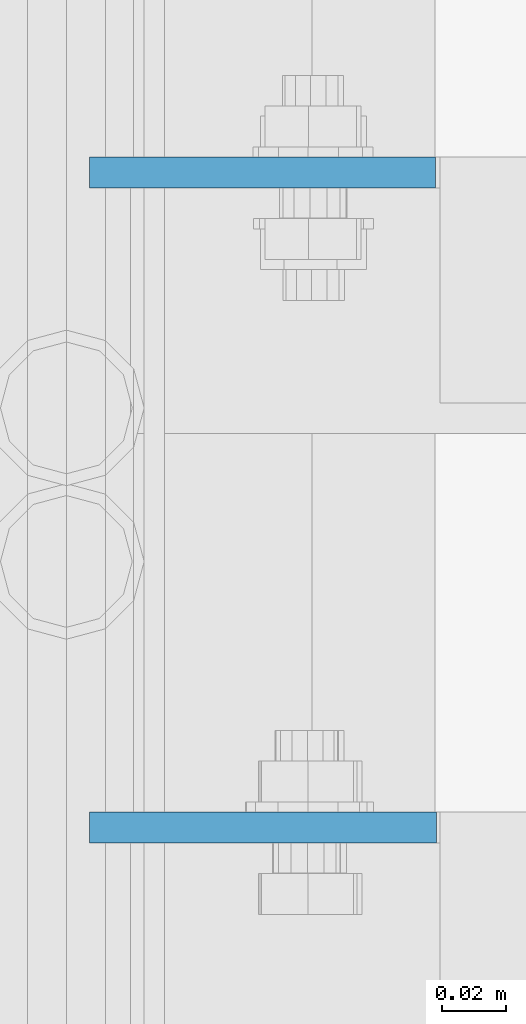
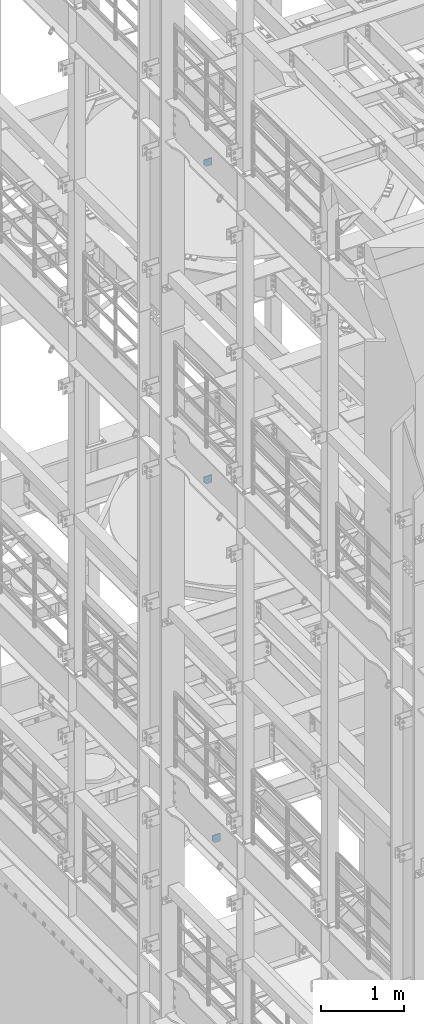
# One storey, part 1686 of 1876: 3 plates, 3 elements without a shape of their own.
"""IFC2X3 building model written with IfcOpenShell, lengths in millimetres."""

from ifc_helpers import new_model, si_unit, frame, origin_with_axes, place, context, subcontext, project, spatial, faceted_brep, material, type_object, element, aggregate, save


model = new_model("IFC2X3")

# Units and contexts
model_context = context("Model", 3, precision=1e-05, world=origin_with_axes())
body_context = subcontext(model_context, "Body", "Model", "MODEL_VIEW")
ifc_project = project(units=[si_unit("LENGTHUNIT", "METRE", prefix="MILLI"), si_unit("AREAUNIT", "SQUARE_METRE"), si_unit("VOLUMEUNIT", "CUBIC_METRE"), si_unit("MASSUNIT", "GRAM", prefix="KILO"), si_unit("TIMEUNIT", "SECOND"), si_unit("PLANEANGLEUNIT", "RADIAN"), si_unit("SOLIDANGLEUNIT", "STERADIAN"), si_unit("THERMODYNAMICTEMPERATUREUNIT", "DEGREE_CELSIUS"), si_unit("LUMINOUSINTENSITYUNIT", "LUMEN")], contexts=[model_context])

# Site, building, storey
site_placement = place(None, origin_with_axes())
site = spatial("IfcSite", under=ifc_project, at=site_placement, CompositionType="ELEMENT")
building_placement = place(site_placement, origin_with_axes())
building = spatial("IfcBuilding", under=site, at=building_placement, Name="Undefined", CompositionType="ELEMENT")
storey_placement = place(building_placement, origin_with_axes())
storey = spatial("IfcBuildingStorey", under=building, at=storey_placement, Name="Undefined", CompositionType="ELEMENT", Elevation=0.0)

# Assembly, plate
assembly_1_placement = place(storey_placement, origin_with_axes())
assembly_1 = element("IfcElementAssembly", 1, at=assembly_1_placement, inside=storey, Name="BEAM", AssemblyPlace="NOTDEFINED", PredefinedType="RIGID_FRAME")
ifc_material = material(Name="STEEL/A36")
plate_type_1 = type_object("IfcPlateType", PredefinedType="NOTDEFINED")
plate_1_placement = place(assembly_1_placement, frame((114.570656047482, 6599.2375, 17386.3), z_axis=(-1.0, 0.0, 0.0), x_axis=(0.0, 0.0, 1.0)))
plate_1 = element("IfcPlate", 2, at=plate_1_placement, type_object=plate_type_1, material=ifc_material, Name="PLATE", context=body_context, shape_type="Brep", body=[
    faceted_brep([(0.0, -4.76249999999982, 0.0), (0.0, -4.76249999999982, 75.6769027709961), (0.0, 4.76249999999982, 75.6769027709961), (0.0, 4.76249999999982, 0.0), (31.75, -4.76249999999982, 107.426902770996), (31.75, 4.76249999999982, 107.426902770996), (106.270881652832, -4.76249999999982, 107.426902770996), (106.270881652832, 4.76249999999982, 107.426902770996), (106.270881652832, -4.76249999999982, 0.0), (106.270881652832, 4.76249999999982, 0.0)], [[[0, 1, 2, 3]], [[1, 4, 5, 2]], [[4, 6, 7, 5]], [[6, 8, 9, 7]], [[8, 0, 3, 9]], [[5, 7, 9, 3, 2]], [[8, 6, 4, 1, 0]]]),
])
aggregate(assembly_1, [plate_1])

assembly_2_placement = place(storey_placement, origin_with_axes())
assembly_2 = element("IfcElementAssembly", 3, at=assembly_2_placement, inside=storey, Name="BEAM", AssemblyPlace="NOTDEFINED", PredefinedType="RIGID_FRAME")
plate_type_2 = type_object("IfcPlateType", PredefinedType="NOTDEFINED")
plate_2_placement = place(assembly_2_placement, frame((7.14375, 6396.0375, 7556.5), z_axis=(0.0, 0.0, 1.0), x_axis=(1.0, 0.0, 0.0)))
plate_2 = element("IfcPlate", 4, at=plate_2_placement, type_object=plate_type_2, material=ifc_material, Name="PLATE", context=body_context, shape_type="Brep", body=[
    faceted_brep([(-9.76996261670138e-14, -4.76250000000073, 31.75), (-4.52970994047064e-14, -4.76249999999982, 114.585624694824), (-4.52970994047064e-14, 4.76249999999982, 114.585624694824), (-9.76996261670138e-14, 4.76250000000073, 31.75), (107.66130065918, -4.76249999999982, 114.585624694824), (107.66130065918, 4.76249999999982, 114.585624694824), (107.66130065918, -4.76249999999982, 0.0), (107.66130065918, 4.76249999999982, 0.0), (31.75, -4.76250000000073, 0.0), (31.75, 4.76250000000073, 0.0)], [[[0, 1, 2, 3]], [[1, 4, 5, 2]], [[4, 6, 7, 5]], [[6, 8, 9, 7]], [[8, 0, 3, 9]], [[5, 7, 9, 3, 2]], [[8, 6, 4, 1, 0]]]),
])
aggregate(assembly_2, [plate_2])

assembly_3_placement = place(storey_placement, origin_with_axes())
assembly_3 = element("IfcElementAssembly", 5, at=assembly_3_placement, inside=storey, Name="BEAM", AssemblyPlace="NOTDEFINED", PredefinedType="RIGID_FRAME")
plate_3_placement = place(assembly_3_placement, frame((7.14374663743973, 6599.23749999999, 12827.2856024578), z_axis=(0.0, 0.0, -1.0), x_axis=(1.0, 0.0, 0.0)))
plate_3 = element("IfcPlate", 6, at=plate_3_placement, type_object=plate_type_2, material=ifc_material, Name="PLATE", context=body_context, shape_type="Brep", body=[
    faceted_brep([(0.0, -4.76249999999982, 0.0), (3.36263383360347e-06, -4.76249999999982, 82.8355941772461), (3.36263383360347e-06, 4.76249999999982, 82.8355941772461), (0.0, 4.76249999999982, 0.0), (31.7500038146972, -4.76249999999982, 114.585594177246), (31.7500038146972, 4.76249999999982, 114.585594177246), (107.335327148437, -4.76249999999982, 114.585594177246), (107.335327148437, 4.76249999999982, 114.585594177246), (107.335327148437, -4.76249999999982, 0.0), (107.335327148437, 4.76249999999982, 0.0)], [[[0, 1, 2, 3]], [[1, 4, 5, 2]], [[4, 6, 7, 5]], [[6, 8, 9, 7]], [[8, 0, 3, 9]], [[5, 7, 9, 3, 2]], [[8, 6, 4, 1, 0]]]),
])
aggregate(assembly_3, [plate_3])

save(model, "model.ifc")
